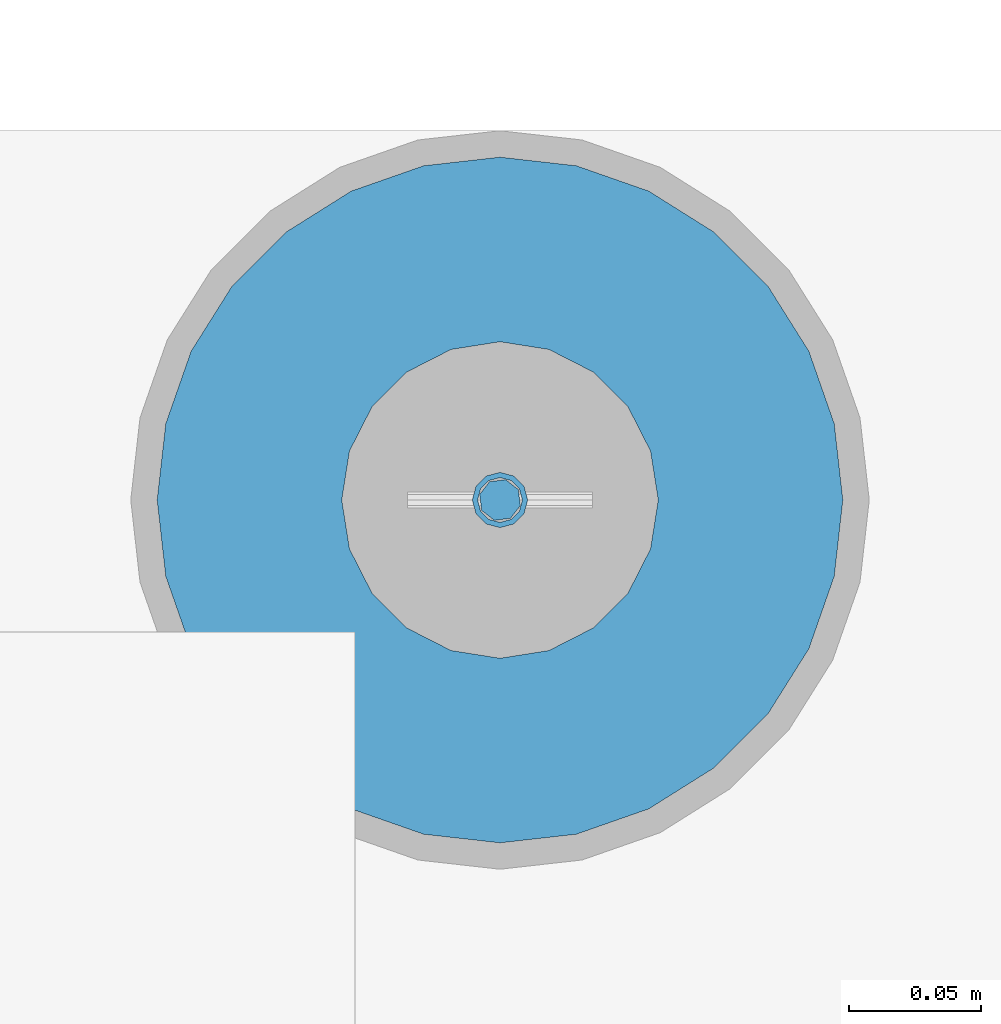
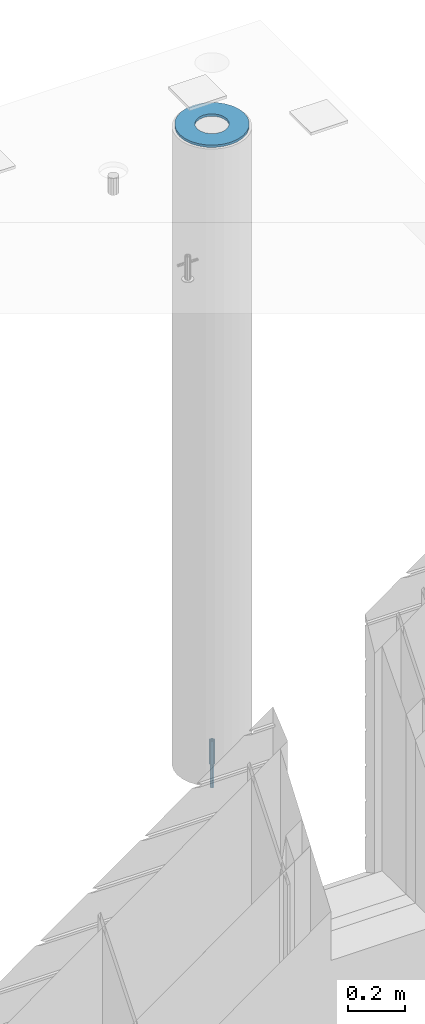
# One storey, part 34 of 309: 3 columns, 3 elements without a shape of their own.
"""IFC2X3 building model written with IfcOpenShell, lengths in millimetres."""

from ifc_helpers import new_model, si_unit, frame, origin_with_axes, place, context, subcontext, project, spatial, faceted_brep, material, type_object, element, aggregate, save


model = new_model("IFC2X3")

# Units and contexts
model_context = context("Model", 3, precision=1e-05, world=origin_with_axes())
body_context = subcontext(model_context, "Body", "Model", "MODEL_VIEW")
ifc_project = project(units=[si_unit("LENGTHUNIT", "METRE", prefix="MILLI"), si_unit("AREAUNIT", "SQUARE_METRE"), si_unit("VOLUMEUNIT", "CUBIC_METRE"), si_unit("MASSUNIT", "GRAM", prefix="KILO"), si_unit("TIMEUNIT", "SECOND"), si_unit("PLANEANGLEUNIT", "RADIAN"), si_unit("SOLIDANGLEUNIT", "STERADIAN"), si_unit("THERMODYNAMICTEMPERATUREUNIT", "DEGREE_CELSIUS"), si_unit("LUMINOUSINTENSITYUNIT", "LUMEN")], contexts=[model_context])

# Site, building, storey
site_placement = place(None, origin_with_axes())
site = spatial("IfcSite", under=ifc_project, at=site_placement, CompositionType="ELEMENT")
building_placement = place(site_placement, origin_with_axes())
building = spatial("IfcBuilding", under=site, at=building_placement, CompositionType="ELEMENT")
storey_placement = place(building_placement, origin_with_axes())
storey = spatial("IfcBuildingStorey", under=building, at=storey_placement, Name="7", CompositionType="ELEMENT", Elevation=0.0)

# Assemblies, columns
assembly_1_placement = place(storey_placement, origin_with_axes())
assembly_1 = element("IfcElementAssembly", 1, at=assembly_1_placement, inside=storey, AssemblyPlace="NOTDEFINED", PredefinedType="REINFORCEMENT_UNIT")
assembly_2_placement = place(assembly_1_placement, origin_with_axes())
assembly_2 = element("IfcElementAssembly", 2, at=assembly_2_placement, Name="Steel Assembly", AssemblyPlace="NOTDEFINED", PredefinedType="RIGID_FRAME")
ifc_material_1 = material(Name="STEEL/S235JR")
column_type_1 = type_object("IfcColumnType", Name="D16", PredefinedType="NOTDEFINED")
column_1_placement = place(assembly_2_placement, frame((35010.0004801435, 22669.9842012047, 99625.0), z_axis=(-0.261346946111888, -0.96524492941325, 0.0), x_axis=(0.0, 0.0, 1.0)))
column_1 = element("IfcColumn", 3, at=column_1_placement, type_object=column_type_1, material=ifc_material_1, Name="M16", ObjectType="D16", context=body_context, shape_type="Brep", body=[
    faceted_brep([(0.0, -8.0, 0.0), (0.0, -5.65685424949334, -5.65685424949334), (150.0, -5.65685424949697, -5.65685424949334), (150.0, -8.00000000000364, 0.0), (0.0, 0.0, -8.0), (150.0, -7.27595761418343e-12, -7.99999999999636), (0.0, 5.65685424949334, -5.65685424949334), (150.0, 5.6568542494897, -5.65685424949334), (0.0, 8.0, 0.0), (150.0, 8.0, -3.63797880709171e-12), (0.0, 5.65685424949334, 5.65685424949334), (150.0, 5.65685424949334, 5.65685424949697), (0.0, 0.0, 8.0), (150.0, -3.63797880709171e-12, 8.0), (0.0, -5.65685424949334, 5.65685424949334), (150.0, -5.65685424949334, 5.6568542494897)], [[[0, 1, 2, 3]], [[1, 4, 5, 2]], [[4, 6, 7, 5]], [[6, 8, 9, 7]], [[8, 10, 11, 9]], [[10, 12, 13, 11]], [[12, 14, 15, 13]], [[14, 0, 3, 15]], [[5, 7, 9, 11, 13, 15, 3, 2]], [[14, 12, 10, 8, 6, 4, 1, 0]]]),
])
aggregate(assembly_2, [column_1])
assembly_3_placement = place(assembly_1_placement, origin_with_axes())
assembly_3 = element("IfcElementAssembly", 4, at=assembly_3_placement, Name="Steel Assembly", AssemblyPlace="NOTDEFINED", PredefinedType="RIGID_FRAME")
ifc_material_2 = material(Name="STEEL/Steel_Undefined")
column_type_2 = type_object("IfcColumnType", PredefinedType="NOTDEFINED")
column_2_placement = place(assembly_3_placement, frame((35009.9987952044, 22669.984888838, 99725.0), z_axis=(0.0, 1.0, 0.0), x_axis=(0.0, 0.0, 1.0)))
column_2 = element("IfcColumn", 5, at=column_2_placement, type_object=column_type_2, material=ifc_material_2, context=body_context, shape_type="Brep", body=[
    faceted_brep([(0.0, -8.49999999999272, -1.45519152283669e-11), (0.0, -7.36121593215648, 4.24999999998545), (100.000000000262, -7.36121593215648, 4.24999999998545), (100.000000000262, -8.49999999999272, -1.45519152283669e-11), (0.0, -4.24999999998545, 7.36121593216376), (100.000000000262, -4.24999999998545, 7.36121593216376), (0.0, 1.45519152283669e-11, 8.49999999998545), (100.000000000262, 1.45519152283669e-11, 8.49999999998545), (0.0, 4.25000000001455, 7.36121593216376), (100.000000000262, 4.25000000001455, 7.36121593216376), (0.0, 7.36121593217104, 4.24999999998545), (100.000000000262, 7.36121593217104, 4.24999999998545), (0.0, 8.50000000000728, 0.0), (100.000000000262, 8.50000000000728, 0.0), (0.0, 7.36121593217104, -4.25000000001455), (100.000000000262, 7.36121593217104, -4.25000000001455), (0.0, 4.25000000000728, -7.36121593219286), (100.000000000262, 4.25000000000728, -7.36121593219286), (0.0, 7.27595761418343e-12, -8.5), (100.000000000262, 7.27595761418343e-12, -8.5), (0.0, -4.24999999999272, -7.36121593217831), (100.000000000262, -4.24999999999272, -7.36121593217831), (0.0, -7.36121593215648, -4.25), (100.000000000262, -7.36121593215648, -4.25), (0.0, -10.4999999999927, -1.45519152283669e-11), (0.0, -9.09326673972828, -5.25000000001455), (100.000000000262, -9.09326673972828, -5.25000000001455), (100.000000000262, -10.4999999999927, -1.45519152283669e-11), (0.0, -5.24999999998545, -9.09326673974283), (100.000000000262, -5.24999999998545, -9.09326673974283), (0.0, 7.27595761418343e-12, -10.5), (100.000000000262, 7.27595761418343e-12, -10.5), (0.0, 5.25000000001455, -9.09326673975738), (100.000000000262, 5.25000000001455, -9.09326673975738), (0.0, 9.09326673975011, -5.25000000001455), (100.000000000262, 9.09326673975011, -5.25000000001455), (0.0, 10.5000000000073, -1.45519152283669e-11), (100.000000000262, 10.5000000000073, -1.45519152283669e-11), (0.0, 9.09326673975011, 5.25), (100.000000000262, 9.09326673975011, 5.25), (0.0, 5.25000000000728, 9.09326673972828), (100.000000000262, 5.25000000000728, 9.09326673972828), (0.0, 1.45519152283669e-11, 10.4999999999854), (100.000000000262, 1.45519152283669e-11, 10.4999999999854), (0.0, -5.24999999999272, 9.09326673972828), (100.000000000262, -5.24999999999272, 9.09326673972828), (0.0, -9.09326673972828, 5.24999999998545), (100.000000000262, -9.09326673972828, 5.24999999998545)], [[[0, 1, 2, 3]], [[1, 4, 5, 2]], [[4, 6, 7, 5]], [[6, 8, 9, 7]], [[8, 10, 11, 9]], [[10, 12, 13, 11]], [[12, 14, 15, 13]], [[14, 16, 17, 15]], [[16, 18, 19, 17]], [[18, 20, 21, 19]], [[20, 22, 23, 21]], [[22, 0, 3, 23]], [[24, 25, 26, 27]], [[25, 28, 29, 26]], [[28, 30, 31, 29]], [[30, 32, 33, 31]], [[32, 34, 35, 33]], [[34, 36, 37, 35]], [[36, 38, 39, 37]], [[38, 40, 41, 39]], [[40, 42, 43, 41]], [[42, 44, 45, 43]], [[44, 46, 47, 45]], [[46, 24, 27, 47]], [[29, 31, 33, 35, 37, 39, 41, 43, 45, 47, 27, 26], [5, 7, 9, 11, 13, 15, 17, 19, 21, 23, 3, 2]], [[46, 44, 42, 40, 38, 36, 34, 32, 30, 28, 25, 24], [22, 20, 18, 16, 14, 12, 10, 8, 6, 4, 1, 0]]]),
])
aggregate(assembly_3, [column_2])
ifc_material_3 = material()
column_type_3 = type_object("IfcColumnType", Name="D260", PredefinedType="NOTDEFINED")
column_3_placement = place(assembly_1_placement, frame((35009.9987952044, 22669.984888838, 102435.0), z_axis=(-1.0, 3.00000001838171e-08, 0.0), x_axis=(0.0, 0.0, 1.0)))
column_3 = element("IfcColumn", 6, at=column_3_placement, type_object=column_type_3, material=ifc_material_3, Name="60", ObjectType="D260", context=body_context, shape_type="Brep", body=[
    faceted_brep([(10.0, -18.541019662498, -57.0633909777098), (0.0, -18.541019662498, -57.0633909777098), (0.0, -35.2671151375471, -48.5410196624944), (10.0, -35.2671151375471, -48.5410196624944), (0.0, -48.541019662498, -35.2671151375471), (10.0, -48.541019662498, -35.2671151375471), (0.0, -57.0633909777098, -18.5410196624944), (10.0, -57.0633909777098, -18.5410196624944), (0.0, -60.0, 0.0), (10.0, -60.0, 0.0), (0.0, -57.0633909777098, 18.5410196624944), (10.0, -57.0633909777098, 18.5410196624944), (0.0, -48.541019662498, 35.2671151375471), (10.0, -48.541019662498, 35.2671151375471), (0.0, -35.2671151375471, 48.5410196624944), (10.0, -35.2671151375471, 48.5410196624944), (0.0, -18.541019662498, 57.0633909777098), (10.0, -18.541019662498, 57.0633909777098), (0.0, 0.0, 60.0), (10.0, 0.0, 60.0), (0.0, 18.541019662498, 57.0633909777098), (10.0, 18.541019662498, 57.0633909777098), (0.0, 35.2671151375471, 48.5410196624944), (10.0, 35.2671151375471, 48.5410196624944), (0.0, 48.541019662498, 35.2671151375471), (10.0, 48.541019662498, 35.2671151375471), (0.0, 57.0633909777098, 18.5410196624944), (10.0, 57.0633909777098, 18.5410196624944), (0.0, 60.0, 0.0), (10.0, 60.0, 0.0), (0.0, 57.0633909777098, -18.5410196624944), (10.0, 57.0633909777098, -18.5410196624944), (0.0, 48.541019662498, -35.2671151375471), (10.0, 48.541019662498, -35.2671151375471), (0.0, 35.2671151375471, -48.5410196624944), (10.0, 35.2671151375471, -48.5410196624944), (0.0, 18.541019662498, -57.0633909777098), (10.0, 18.541019662498, -57.0633909777098), (0.0, 0.0, -60.0), (10.0, 0.0, -60.0), (0.0, -126.740628583637, -28.9277214143222), (0.0, -117.125952827315, -56.4048860852854), (10.0, -117.125952827315, -56.4048860852854), (10.0, -126.740628583637, -28.9277214143222), (0.0, -101.638092720845, -81.0536742416371), (10.0, -101.638092720845, -81.0536742416371), (0.0, -81.0536742416371, -101.638092720845), (10.0, -81.0536742416371, -101.638092720845), (0.0, -56.4048860852818, -117.125952827315), (10.0, -56.4048860852818, -117.125952827315), (0.0, -28.9277214143222, -126.740628583641), (10.0, -28.9277214143222, -126.740628583641), (0.0, 0.0, -130.0), (10.0, 0.0, -130.0), (0.0, 28.9277214143222, -126.740628583641), (10.0, 28.9277214143222, -126.740628583641), (0.0, 56.4048860852818, -117.125952827315), (10.0, 56.4048860852818, -117.125952827315), (0.0, 81.0536742416371, -101.638092720845), (10.0, 81.0536742416371, -101.638092720845), (0.0, 101.638092720845, -81.0536742416371), (10.0, 101.638092720845, -81.0536742416371), (0.0, 117.125952827315, -56.4048860852854), (10.0, 117.125952827315, -56.4048860852854), (0.0, 126.740628583637, -28.9277214143222), (10.0, 126.740628583637, -28.9277214143222), (0.0, 130.0, -1.81898940354586e-12), (10.0, 130.0, 0.0), (0.0, 126.740628583637, 28.9277214143222), (10.0, 126.740628583637, 28.9277214143222), (0.0, 117.125952827315, 56.4048860852854), (10.0, 117.125952827315, 56.4048860852854), (0.0, 101.638092720845, 81.0536742416371), (10.0, 101.638092720845, 81.0536742416371), (0.0, 81.0536742416371, 101.638092720845), (10.0, 81.0536742416371, 101.638092720845), (0.0, 56.4048860852818, 117.125952827315), (10.0, 56.4048860852818, 117.125952827315), (0.0, 28.9277214143222, 126.740628583641), (10.0, 28.9277214143222, 126.740628583641), (0.0, 0.0, 130.0), (10.0, 0.0, 130.0), (0.0, -28.9277214143222, 126.740628583641), (10.0, -28.9277214143222, 126.740628583641), (0.0, -56.4048860852818, 117.125952827315), (10.0, -56.4048860852818, 117.125952827315), (0.0, -81.0536742416371, 101.638092720845), (10.0, -81.0536742416371, 101.638092720845), (0.0, -101.638092720845, 81.0536742416371), (10.0, -101.638092720845, 81.0536742416371), (0.0, -117.125952827315, 56.4048860852854), (10.0, -117.125952827315, 56.4048860852854), (0.0, -126.740628583637, 28.9277214143222), (10.0, -126.740628583637, 28.9277214143222), (0.0, -130.0, -3.63797880709171e-12), (10.0, -130.0, 0.0)], [[[0, 1, 2, 3]], [[3, 2, 4, 5]], [[5, 4, 6, 7]], [[7, 6, 8, 9]], [[9, 8, 10, 11]], [[11, 10, 12, 13]], [[13, 12, 14, 15]], [[15, 14, 16, 17]], [[17, 16, 18, 19]], [[19, 18, 20, 21]], [[21, 20, 22, 23]], [[23, 22, 24, 25]], [[25, 24, 26, 27]], [[27, 26, 28, 29]], [[29, 28, 30, 31]], [[31, 30, 32, 33]], [[33, 32, 34, 35]], [[35, 34, 36, 37]], [[37, 36, 38, 39]], [[39, 38, 1, 0]], [[40, 41, 42, 43]], [[41, 44, 45, 42]], [[44, 46, 47, 45]], [[46, 48, 49, 47]], [[48, 50, 51, 49]], [[50, 52, 53, 51]], [[52, 54, 55, 53]], [[54, 56, 57, 55]], [[56, 58, 59, 57]], [[58, 60, 61, 59]], [[60, 62, 63, 61]], [[62, 64, 65, 63]], [[64, 66, 67, 65]], [[66, 68, 69, 67]], [[68, 70, 71, 69]], [[70, 72, 73, 71]], [[72, 74, 75, 73]], [[74, 76, 77, 75]], [[76, 78, 79, 77]], [[78, 80, 81, 79]], [[80, 82, 83, 81]], [[82, 84, 85, 83]], [[84, 86, 87, 85]], [[86, 88, 89, 87]], [[88, 90, 91, 89]], [[90, 92, 93, 91]], [[92, 94, 95, 93]], [[42, 45, 47, 49, 51, 53, 55, 57, 59, 61, 63, 65, 67, 69, 71, 73, 75, 77, 79, 81, 83, 85, 87, 89, 91, 93, 95, 43], [3, 5, 7, 9, 11, 13, 15, 17, 19, 21, 23, 25, 27, 29, 31, 33, 35, 37, 39, 0]], [[94, 40, 43, 95]], [[92, 90, 88, 86, 84, 82, 80, 78, 76, 74, 72, 70, 68, 66, 64, 62, 60, 58, 56, 54, 52, 50, 48, 46, 44, 41, 40, 94], [34, 32, 30, 28, 26, 24, 22, 20, 18, 16, 14, 12, 10, 8, 6, 4, 2, 1, 38, 36]]]),
])
aggregate(assembly_1, [assembly_3, assembly_2, column_3])

save(model, "model.ifc")
